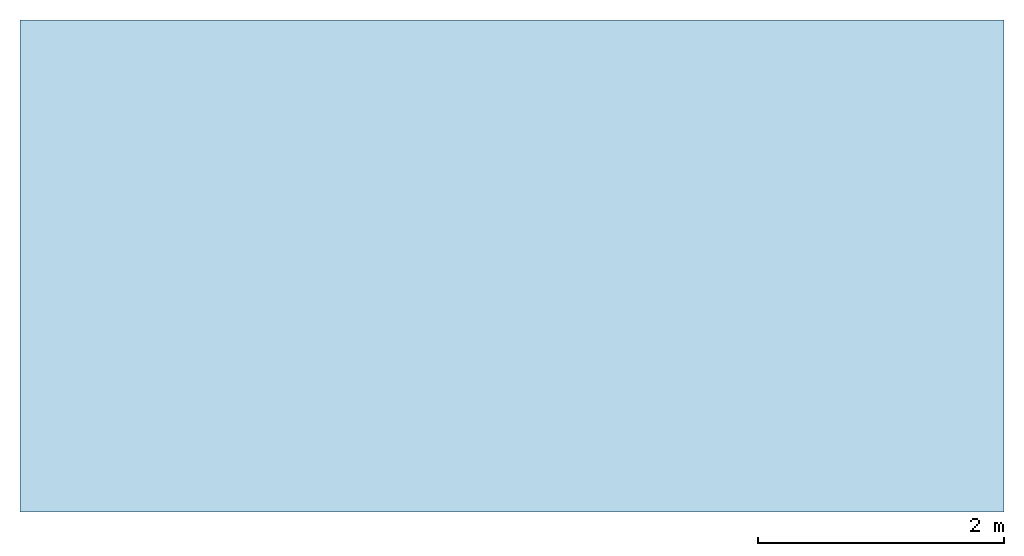
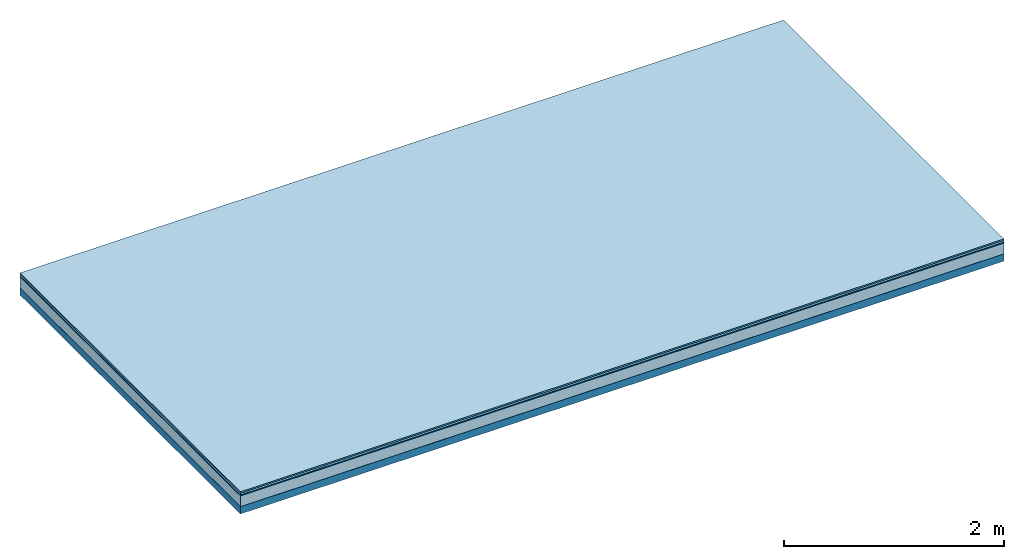
# One storey: 5 plates, 1 member, 1 element without a shape of its own.
"""IFC4 building model written with IfcOpenShell, lengths in metres."""

from ifc_helpers import new_model, si_unit, derived_unit, direction, frame, frame_2d, origin, origin_with_axes, place, context, project, spatial, rectangle, extrude, material, layer, layer_set, type_object, element, aggregate, save


model = new_model("IFC4")

# Units and contexts
plan_context = context("Plan", 3, precision=1e-05, world=origin(), true_north=direction((0.0, 1.0)))
model_context = context("Model", 3, precision=1e-05, world=origin(), true_north=direction((0.0, 1.0)))
ifc_project = project(units=[si_unit("LENGTHUNIT", "METRE"), derived_unit("SOUNDPRESSUREUNIT", [(si_unit("PRESSUREUNIT", "PASCAL", prefix="MICRO"), 0)]), si_unit("ENERGYUNIT", "JOULE", prefix="MEGA"), si_unit("MASSUNIT", "GRAM", prefix="KILO"), derived_unit("THERMALTRANSMITTANCEUNIT", [(si_unit("POWERUNIT", "WATT"), 1), (si_unit("AREAUNIT", "SQUARE_METRE"), -1), (si_unit("THERMODYNAMICTEMPERATUREUNIT", "KELVIN"), -1)]), derived_unit("AREADENSITYUNIT", [(si_unit("MASSUNIT", "GRAM", prefix="KILO"), 1), (si_unit("AREAUNIT", "SQUARE_METRE"), -1)]), derived_unit("USERDEFINED", [(si_unit("ENERGYUNIT", "JOULE", prefix="MEGA"), 1), (si_unit("AREAUNIT", "SQUARE_METRE"), -1)])], contexts=[plan_context, model_context])

# Site, building, storey
site = spatial("IfcSite", under=ifc_project)
building_placement = place(None, origin())
building = spatial("IfcBuilding", under=site, at=building_placement)
storey_placement = place(building_placement, origin())
storey = spatial("IfcBuildingStorey", under=building, at=storey_placement)

# Slab, member, plates
ifc_material_1 = material(Category="11.013")
ifc_layer_1 = layer(ifc_material_1, 0.015, Name="Flooring")
ifc_material_2 = material(Category="03.007")
ifc_layer_2 = layer(ifc_material_2, 0.02, Name="On-material")
ifc_material_3 = material(Name="Wood fiber generic product", Category="10.009")
ifc_layer_3 = layer(ifc_material_3, 0.01, Name="Impact sound insulation")
ifc_material_4 = material(Category="03.011")
ifc_layer_4 = layer(ifc_material_4, 0.12, Name="on Supporting structure")
ifc_material_5 = material(Name="protection", Category="09.007")
ifc_layer_5 = layer(ifc_material_5, 0.0005, Name="Sub-floor")
ifc_material_6 = material(Name="no composite action")
ifc_layer_6 = layer(ifc_material_6, 0.0, Name="Bond")
ifc_layer_7 = layer(None, 0.08, Name="Supporting structure")
ifc_layer_set = layer_set([ifc_layer_1, ifc_layer_2, ifc_layer_3, ifc_layer_4, ifc_layer_5, ifc_layer_6, ifc_layer_7])
slab_type = type_object("IfcSlabType", Name="A2049", PredefinedType="NOTDEFINED", material=ifc_layer_set)
slab_placement = place(None, frame((0.0, 0.0, 0.0), z_axis=(0.0, 0.0, -1.0), x_axis=(1.0, 0.0, 0.0)))
slab = element("IfcSlab", 1, at=slab_placement, inside=storey, type_object=slab_type, material=ifc_layer_set, Name="Slab #1")
ifc_material_7 = material(Name="Solid timber panel")
member_placement = place(slab_placement, origin())
member = element("IfcMember", 2, at=member_placement, material=ifc_material_7, Name="Supporting structure", context=plan_context, shape_type="SweptSolid", body=[
    extrude(rectangle(XDim=1.0, YDim=0.08, at=frame_2d((0.5, 0.04), x_axis=(1.0, 0.0))), frame((0.0, 4.0, 0.1655), z_axis=(0.0, -1.0, 0.0), x_axis=(1.0, 0.0, 0.0)), (0.0, 0.0, 1.0), 4.0),
    extrude(rectangle(XDim=1.0, YDim=0.08, at=frame_2d((0.5, 0.04), x_axis=(1.0, 0.0))), frame((1.0, 4.0, 0.1655), z_axis=(0.0, -1.0, 0.0), x_axis=(1.0, 0.0, 0.0)), (0.0, 0.0, 1.0), 4.0),
    extrude(rectangle(XDim=1.0, YDim=0.08, at=frame_2d((0.5, 0.04), x_axis=(1.0, 0.0))), frame((2.0, 4.0, 0.1655), z_axis=(0.0, -1.0, 0.0), x_axis=(1.0, 0.0, 0.0)), (0.0, 0.0, 1.0), 4.0),
    extrude(rectangle(XDim=1.0, YDim=0.08, at=frame_2d((0.5, 0.04), x_axis=(1.0, 0.0))), frame((3.0, 4.0, 0.1655), z_axis=(0.0, -1.0, 0.0), x_axis=(1.0, 0.0, 0.0)), (0.0, 0.0, 1.0), 4.0),
    extrude(rectangle(XDim=1.0, YDim=0.08, at=frame_2d((0.5, 0.04), x_axis=(1.0, 0.0))), frame((4.0, 4.0, 0.1655), z_axis=(0.0, -1.0, 0.0), x_axis=(1.0, 0.0, 0.0)), (0.0, 0.0, 1.0), 4.0),
    extrude(rectangle(XDim=1.0, YDim=0.08, at=frame_2d((0.5, 0.04), x_axis=(1.0, 0.0))), frame((5.0, 4.0, 0.1655), z_axis=(0.0, -1.0, 0.0), x_axis=(1.0, 0.0, 0.0)), (0.0, 0.0, 1.0), 4.0),
    extrude(rectangle(XDim=1.0, YDim=0.08, at=frame_2d((0.5, 0.04), x_axis=(1.0, 0.0))), frame((6.0, 4.0, 0.1655), z_axis=(0.0, -1.0, 0.0), x_axis=(1.0, 0.0, 0.0)), (0.0, 0.0, 1.0), 4.0),
    extrude(rectangle(XDim=1.0, YDim=0.08, at=frame_2d((0.5, 0.04), x_axis=(1.0, 0.0))), frame((7.0, 4.0, 0.1655), z_axis=(0.0, -1.0, 0.0), x_axis=(1.0, 0.0, 0.0)), (0.0, 0.0, 1.0), 4.0),
])
plate_1_placement = place(slab_placement, origin())
plate_1 = element("IfcPlate", 3, at=plate_1_placement, material=ifc_material_1, Name="Flooring", context=plan_context, shape_type="SweptSolid", body=[
    extrude(rectangle(XDim=8.0, YDim=4.0, at=frame_2d((4.0, 2.0), x_axis=(1.0, 0.0))), origin_with_axes(), (0.0, 0.0, 1.0), 0.015),
])
plate_2_placement = place(slab_placement, origin())
plate_2 = element("IfcPlate", 4, at=plate_2_placement, material=ifc_material_2, Name="On-material", context=plan_context, shape_type="SweptSolid", body=[
    extrude(rectangle(XDim=8.0, YDim=4.0, at=frame_2d((4.0, 2.0), x_axis=(1.0, 0.0))), frame((0.0, 0.0, 0.015), z_axis=(0.0, 0.0, 1.0), x_axis=(1.0, 0.0, 0.0)), (0.0, 0.0, 1.0), 0.02),
])
plate_3_placement = place(slab_placement, origin())
plate_3 = element("IfcPlate", 5, at=plate_3_placement, material=ifc_material_3, Name="Impact sound insulation", context=plan_context, shape_type="SweptSolid", body=[
    extrude(rectangle(XDim=8.0, YDim=4.0, at=frame_2d((4.0, 2.0), x_axis=(1.0, 0.0))), frame((0.0, 0.0, 0.035), z_axis=(0.0, 0.0, 1.0), x_axis=(1.0, 0.0, 0.0)), (0.0, 0.0, 1.0), 0.01),
])
plate_4_placement = place(slab_placement, origin())
plate_4 = element("IfcPlate", 6, at=plate_4_placement, material=ifc_material_4, Name="on Supporting structure", context=plan_context, shape_type="SweptSolid", body=[
    extrude(rectangle(XDim=8.0, YDim=4.0, at=frame_2d((4.0, 2.0), x_axis=(1.0, 0.0))), frame((0.0, 0.0, 0.045), z_axis=(0.0, 0.0, 1.0), x_axis=(1.0, 0.0, 0.0)), (0.0, 0.0, 1.0), 0.12),
])
plate_5_placement = place(slab_placement, origin())
plate_5 = element("IfcPlate", 7, at=plate_5_placement, material=ifc_material_5, Name="Sub-floor", context=plan_context, shape_type="SweptSolid", body=[
    extrude(rectangle(XDim=8.0, YDim=4.0, at=frame_2d((4.0, 2.0), x_axis=(1.0, 0.0))), frame((0.0, 0.0, 0.165), z_axis=(0.0, 0.0, 1.0), x_axis=(1.0, 0.0, 0.0)), (0.0, 0.0, 1.0), 0.0005),
])
aggregate(slab, [plate_1, plate_2, plate_3, plate_4, plate_5, member])

save(model, "model.ifc")
